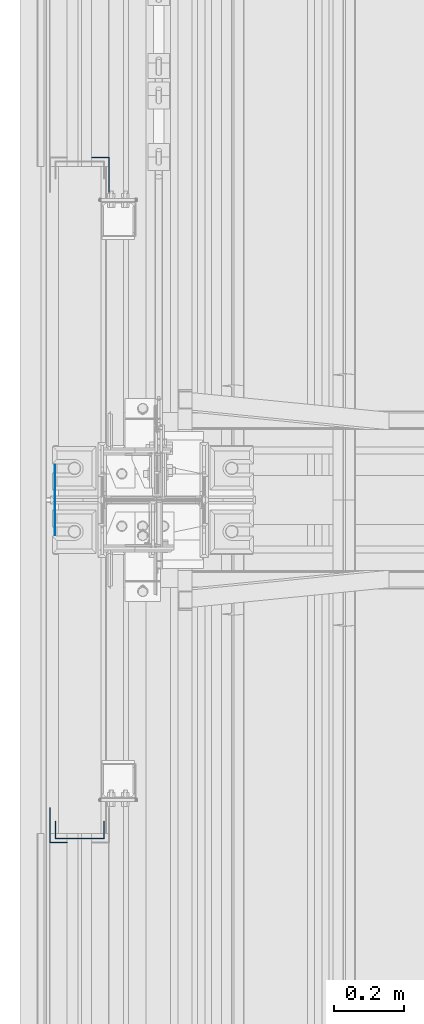
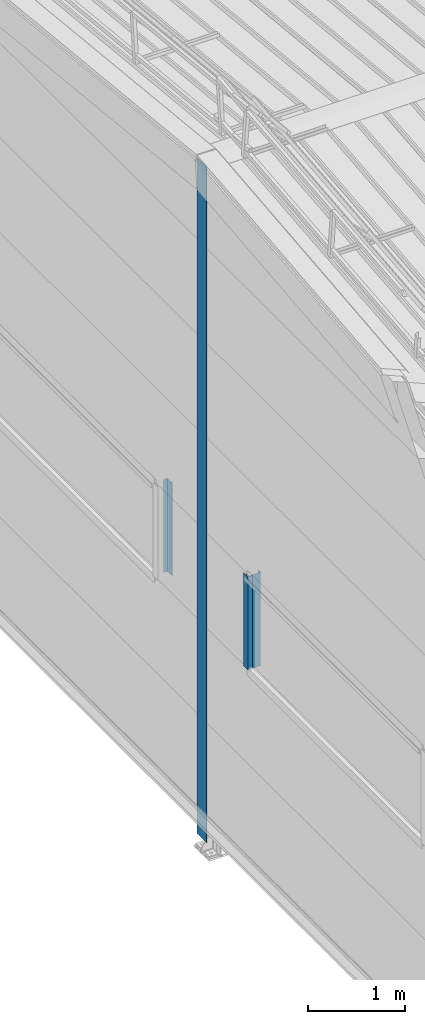
# One storey, part 4 of 709: 4 columns, 4 elements without a shape of their own.
"""IFC4 building model written with IfcOpenShell, lengths in millimetres."""

from ifc_helpers import new_model, si_unit, direction, frame, origin_with_axes, place, context, subcontext, project, spatial, line, indexed_curve, outline, extrude, material, element, aggregate, save


model = new_model("IFC4")

# Units and contexts
model_context = context("Model", 3, precision=0.2, world=origin_with_axes(), true_north=direction((0.0, 1.0)))
body_context = subcontext(model_context, "Body", "Model", "MODEL_VIEW")
ifc_project = project(units=[si_unit("LENGTHUNIT", "METRE", prefix="MILLI"), si_unit("AREAUNIT", "SQUARE_METRE"), si_unit("VOLUMEUNIT", "CUBIC_METRE"), si_unit("MASSUNIT", "GRAM", prefix="KILO"), si_unit("TIMEUNIT", "SECOND"), si_unit("PLANEANGLEUNIT", "RADIAN"), si_unit("SOLIDANGLEUNIT", "STERADIAN"), si_unit("THERMODYNAMICTEMPERATUREUNIT", "DEGREE_CELSIUS"), si_unit("LUMINOUSINTENSITYUNIT", "LUMEN")], contexts=[model_context])

# Site, building, storey
site_placement = place(None, origin_with_axes())
site = spatial("IfcSite", under=ifc_project, at=site_placement, CompositionType="ELEMENT")
building_placement = place(site_placement, origin_with_axes())
building = spatial("IfcBuilding", under=site, at=building_placement, Name="Undefined", CompositionType="ELEMENT")
storey_placement = place(building_placement, origin_with_axes())
storey = spatial("IfcBuildingStorey", under=building, at=storey_placement, Name="Undefined", CompositionType="ELEMENT", Elevation=0.0)

# Assembly, column
assembly_1_placement = place(storey_placement, frame((-60.0, 10060.0, 2700.0), z_axis=(1.0, 0.0, 0.0), x_axis=(0.0, 0.0, 1.0)))
assembly_1 = element("IfcElementAssembly", 1, at=assembly_1_placement, inside=storey)
ifc_material = material(Name="Steel_Undefined", Category="STEEL")
column_1_placement = place(assembly_1_placement, origin_with_axes())
column_1 = element("IfcColumn", 2, at=column_1_placement, material=ifc_material, context=body_context, shape_type="SolidModel", body=[
    extrude(outline(indexed_curve([(-70.0, -25.0), (-68.0, -25.0), (-68.0, 23.0), (68.0, 23.0), (68.0, -25.0), (70.0, -25.0), (70.0, 25.0), (-70.0, 25.0)], segments=[line(1, 2, 3, 4, 5, 6, 7, 8, 1)])), frame((0.0, 0.0, 0.0), z_axis=(-1.0, 0.0, 0.0), x_axis=(0.0, 0.0, 1.0)), (0.0, 0.0, -1.0), 1170.0),
])
aggregate(assembly_1, [column_1])

assembly_2_placement = place(storey_placement, frame((-121.0, 10025.0, 2700.0), z_axis=(-1.0, 0.0, 0.0), x_axis=(0.0, 0.0, 1.0)))
assembly_2 = element("IfcElementAssembly", 3, at=assembly_2_placement, inside=storey)
column_2_placement = place(assembly_2_placement, origin_with_axes())
column_2 = element("IfcColumn", 4, at=column_2_placement, material=ifc_material, context=body_context, shape_type="SolidModel", body=[
    extrude(outline(indexed_curve([(-25.0, -1.0), (25.0, -1.0), (25.0, 99.0), (23.0, 99.0), (23.0, 1.0), (-25.0, 1.0)], segments=[line(1, 2, 3, 4, 5, 6, 1)])), frame((0.0, 0.0, 0.0), z_axis=(-1.0, 0.0, 0.0), x_axis=(0.0, 0.0, 1.0)), (0.0, 0.0, -1.0), 1170.0),
])
aggregate(assembly_2, [column_2])

assembly_3_placement = place(storey_placement, frame((-1.0, 11975.0, 2700.0), z_axis=(1.0, 0.0, 0.0), x_axis=(0.0, 0.0, 1.0)))
assembly_3 = element("IfcElementAssembly", 5, at=assembly_3_placement, inside=storey)
column_3_placement = place(assembly_3_placement, origin_with_axes())
column_3 = element("IfcColumn", 6, at=column_3_placement, material=ifc_material, context=body_context, shape_type="SolidModel", body=[
    extrude(outline(indexed_curve([(-25.0, -1.0), (25.0, -1.0), (25.0, 99.0), (23.0, 99.0), (23.0, 1.0), (-25.0, 1.0)], segments=[line(1, 2, 3, 4, 5, 6, 1)])), frame((0.0, 0.0, 0.0), z_axis=(-1.0, 0.0, 0.0), x_axis=(0.0, 0.0, 1.0)), (0.0, 0.0, -1.0), 1170.0),
])
aggregate(assembly_3, [column_3])

assembly_4_placement = place(storey_placement, frame((-130.0, 11000.0, 0.0), z_axis=(-1.0, 0.0, 0.0), x_axis=(0.0, 0.0, 1.0)))
assembly_4 = element("IfcElementAssembly", 7, at=assembly_4_placement, inside=storey)
column_4_placement = place(assembly_4_placement, origin_with_axes())
column_4 = element("IfcColumn", 8, at=column_4_placement, material=ifc_material, context=body_context, shape_type="SolidModel", body=[
    extrude(outline(indexed_curve([(-0.375, -100.0), (1.245, -100.0), (1.245, -50.0), (0.495, -50.0), (0.495, -99.25), (0.375, -99.25), (0.375, 99.25), (0.495, 99.25), (0.495, 50.0), (1.245, 50.0), (1.245, 100.0), (-0.375, 100.0)], segments=[line(1, 2, 3, 4, 5, 6, 7, 8, 9, 10, 11, 12, 1)])), frame((0.0, 0.0, 0.0), z_axis=(-1.0, 0.0, 0.0), x_axis=(0.0, 0.0, 1.0)), (0.0, 0.0, -1.0), 8479.67111),
])
aggregate(assembly_4, [column_4])

save(model, "model.ifc")
